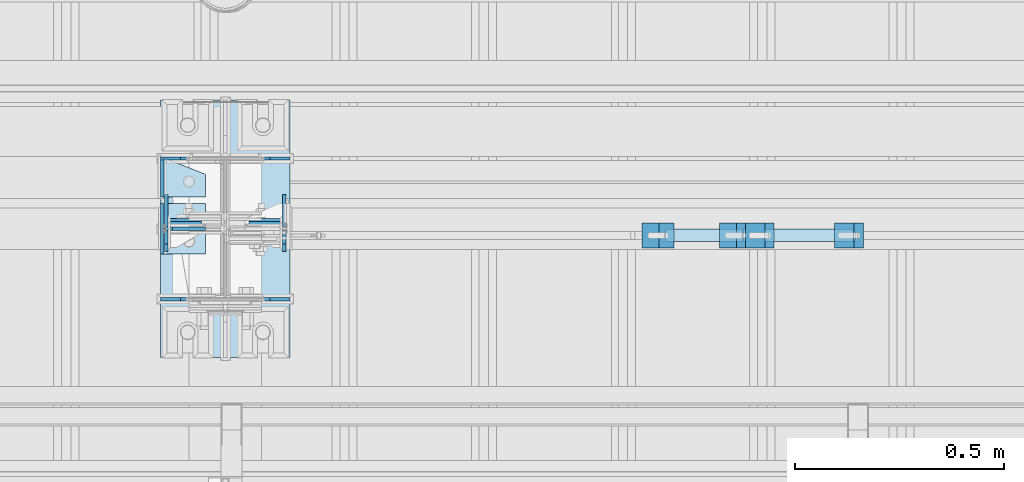
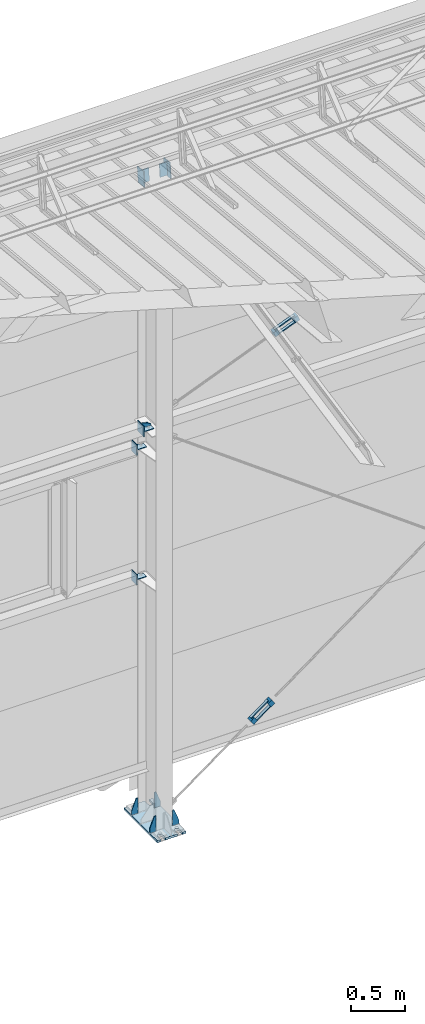
# One storey, part 140 of 709: 24 plates, 4 openings, 8 elements without a shape of their own.
"""IFC4 building model written with IfcOpenShell, lengths in millimetres."""

import ifcopenshell
import ifcopenshell.guid

model = None  # the IFC model being written
_history = None  # IfcOwnerHistory: only IFC2X3 demands one
_inside = {}  # id of a spatial element -> (the spatial element, [elements in it])
_under = {}  # id of a project, library or spatial element -> (it, [spatial elements below it])
_declared = {}  # id of a project -> (the project, [libraries it declares])
_typed = {}  # id of a type object -> (the type object, [elements of that type])
_made_of = {}  # id of a material, layer set ... -> (it, [elements and type objects made of it])


def new_model(schema):
    """Start an empty IFC model of exactly this schema.

    Asked for "IFC4X3", IfcOpenShell would pick the latest addendum, in which some entities
    have other attributes; the version numbers below select the first issue.
    IFC2X3 requires an IfcOwnerHistory on every rooted entity: one is made here for all.
    """
    global model, _history
    if schema == "IFC4X3":
        model = ifcopenshell.file(schema_version=(4, 3, 0, 0))
    else:
        model = ifcopenshell.file(schema=schema)
    _inside.clear()
    _under.clear()
    _declared.clear()
    _typed.clear()
    _made_of.clear()
    _history = None
    if model.schema == "IFC2X3":
        org = make("IfcOrganization", Name="unknown")
        user = make(
            "IfcPersonAndOrganization",
            ThePerson=make("IfcPerson", FamilyName="unknown"),
            TheOrganization=org,
        )
        app = make(
            "IfcApplication",
            ApplicationDeveloper=org,
            Version="unknown",
            ApplicationFullName="unknown",
            ApplicationIdentifier="unknown",
        )
        _history = make(
            "IfcOwnerHistory",
            OwningUser=user,
            OwningApplication=app,
            ChangeAction="ADDED",
            CreationDate=0,
        )
    return model


def make(cls, **values):
    """One entity of the class cls with the attributes given. An attribute that is None is left unset."""
    return model.create_entity(
        cls, **{name: value for name, value in values.items() if value is not None}
    )


def rooted(cls, **values):
    """An entity with a GlobalId (a new one), such as an element, a storey or a relation."""
    return make(cls, GlobalId=ifcopenshell.guid.new(), OwnerHistory=_history, **values)


def si_unit(unit_type, name, prefix=None):
    """IfcSIUnit, for example si_unit("LENGTHUNIT", "METRE", prefix="MILLI")."""
    return make("IfcSIUnit", UnitType=unit_type, Prefix=prefix, Name=name)


def assignment(units):
    """IfcUnitAssignment: the units of a project."""
    return None if units is None else make("IfcUnitAssignment", Units=units)


def point(xyz):
    """IfcCartesianPoint."""
    return None if xyz is None else make("IfcCartesianPoint", Coordinates=xyz)


def direction(xyz):
    """IfcDirection."""
    return None if xyz is None else make("IfcDirection", DirectionRatios=xyz)


def frame(location, z_axis=None, x_axis=None):
    """IfcAxis2Placement3D, a coordinate frame: its origin and axes. An axis left out is left unset."""
    return make(
        "IfcAxis2Placement3D",
        Location=point(location),
        Axis=direction(z_axis),
        RefDirection=direction(x_axis),
    )


def origin_with_axes():
    """The frame at (0, 0, 0) with the z axis (0, 0, 1) and the x axis (1, 0, 0) written out."""
    return frame((0.0, 0.0, 0.0), z_axis=(0.0, 0.0, 1.0), x_axis=(1.0, 0.0, 0.0))


def place(relative_to, where):
    """IfcLocalPlacement: puts the frame where relative to a parent placement (None: the world)."""
    return make(
        "IfcLocalPlacement", PlacementRelTo=relative_to, RelativePlacement=where
    )


def context(
    kind, dimensions, precision=None, world=None, true_north=None, identifier=None
):
    """IfcGeometricRepresentationContext, for example the 3D "Model" context."""
    return make(
        "IfcGeometricRepresentationContext",
        ContextIdentifier=identifier,
        ContextType=kind,
        CoordinateSpaceDimension=dimensions,
        Precision=precision,
        WorldCoordinateSystem=world,
        TrueNorth=true_north,
    )


def subcontext(parent, identifier, kind, view, scale=None):
    """IfcGeometricRepresentationSubContext, for example "Body" below "Model"."""
    return make(
        "IfcGeometricRepresentationSubContext",
        ContextIdentifier=identifier,
        ContextType=kind,
        ParentContext=parent,
        TargetScale=scale,
        TargetView=view,
    )


def project(units=None, contexts=None):
    """IfcProject with its units and contexts."""
    return rooted(
        "IfcProject",
        Name="project",
        RepresentationContexts=contexts,
        UnitsInContext=assignment(units),
    )


def spatial(cls, under=None, at=None, **own):
    """A site, building, storey or space (cls), placed at a placement, below another one or the project."""
    s = rooted(cls, ObjectPlacement=at, **own)
    if under is not None:
        _under.setdefault(under.id(), (under, []))[1].append(s)
    return s


def point_list(points):
    """IfcCartesianPointList2D or 3D."""
    cls = (
        "IfcCartesianPointList2D" if len(points[0]) == 2 else "IfcCartesianPointList3D"
    )
    return make(cls, CoordList=points)


def line(*indices):
    """IfcLineIndex: a straight run through numbered points of an indexed curve."""
    return model.create_entity("IfcLineIndex", indices)


def arc(*indices):
    """IfcArcIndex: an arc through three numbered points of an indexed curve."""
    return model.create_entity("IfcArcIndex", indices)


def indexed_curve(points, segments=None, self_intersect=None):
    """IfcIndexedPolyCurve: lines and arcs through numbered points (the first is 1)."""
    return make(
        "IfcIndexedPolyCurve",
        Points=point_list(points),
        Segments=segments,
        SelfIntersect=self_intersect,
    )


def outline(outer, holes=None, kind="AREA"):
    """IfcArbitraryClosedProfileDef: a profile drawn as a closed curve; with holes, ...WithVoids."""
    if holes is None:
        return make("IfcArbitraryClosedProfileDef", ProfileType=kind, OuterCurve=outer)
    return make(
        "IfcArbitraryProfileDefWithVoids",
        ProfileType=kind,
        OuterCurve=outer,
        InnerCurves=holes,
    )


def extrude(swept, where, along, depth):
    """IfcExtrudedAreaSolid: the profile swept, set in the frame where, extruded along a direction by depth."""
    return make(
        "IfcExtrudedAreaSolid",
        SweptArea=swept,
        Position=where,
        ExtrudedDirection=direction(along),
        Depth=depth,
    )


def shape(context_of_items, identifier, shape_type, items):
    """IfcShapeRepresentation: the items that make up one representation, for example the "Body"."""
    return make(
        "IfcShapeRepresentation",
        ContextOfItems=context_of_items,
        RepresentationIdentifier=identifier,
        RepresentationType=shape_type,
        Items=items,
    )


def material(Name=None, Category=None):
    """IfcMaterial."""
    return make("IfcMaterial", Name=Name, Category=Category)


def made_of(thing, what):
    """Note that an element or type object is made of a material, layer set ...; save() writes the relation."""
    if what is not None:
        _made_of.setdefault(what.id(), (what, []))[1].append(thing)
    return thing


def element(
    cls,
    number,
    at=None,
    inside=None,
    cuts=None,
    type_object=None,
    material=None,
    context=None,
    identifier="Body",
    shape_type=None,
    held_by="IfcProductDefinitionShape",
    body=None,
    shapes=None,
    **own,
):
    """One element of the class cls, such as IfcWall. Its Tag is "e" and its number.

    at: its placement. inside: the storey or other place that contains it. cuts: it is an
    opening in that element (IfcRelVoidsElement). A single representation is given by context,
    identifier, shape_type and body (its items); several are given by shapes. held_by: the class
    of the entity that holds the representations. save() writes the other relations.
    """
    e = rooted(cls, Tag="e%d" % number, ObjectPlacement=at, **own)
    if body is not None:
        shapes = [shape(context, identifier, shape_type, body)]
    if shapes is not None:
        e.Representation = make(held_by, Representations=shapes)
    if inside is not None:
        _inside.setdefault(inside.id(), (inside, []))[1].append(e)
    if cuts is not None:
        rooted(
            "IfcRelVoidsElement", RelatingBuildingElement=cuts, RelatedOpeningElement=e
        )
    if type_object is not None:
        _typed.setdefault(type_object.id(), (type_object, []))[1].append(e)
    return made_of(e, material)


def aggregate(whole, parts):
    """IfcRelAggregates: a whole, such as a stair, and the parts it consists of."""
    return rooted("IfcRelAggregates", RelatingObject=whole, RelatedObjects=parts)


def save(model, path):
    """Write the relations noted so far, then the file.

    IfcRelAggregates (storeys below a building ...), IfcRelContainedInSpatialStructure (elements
    in a storey), IfcRelDefinesByType, IfcRelAssociatesMaterial and IfcRelDeclares: one each for
    every whole, place, type object, material and project.
    """
    for whole, parts in _under.values():
        aggregate(whole, parts)
    for where, things in _inside.values():
        rooted(
            "IfcRelContainedInSpatialStructure",
            RelatedElements=things,
            RelatingStructure=where,
        )
    for kind, things in _typed.values():
        rooted("IfcRelDefinesByType", RelatedObjects=things, RelatingType=kind)
    for what, things in _made_of.values():
        rooted("IfcRelAssociatesMaterial", RelatedObjects=things, RelatingMaterial=what)
    for by, libraries in _declared.values():
        rooted("IfcRelDeclares", RelatingContext=by, RelatedDefinitions=libraries)
    model.write(path)


model = new_model("IFC4")

# Units and contexts
model_context = context("Model", 3, precision=0.2, world=origin_with_axes(), true_north=direction((0.0, 1.0)))
body_context = subcontext(model_context, "Body", "Model", "MODEL_VIEW")
ifc_project = project(units=[si_unit("LENGTHUNIT", "METRE", prefix="MILLI"), si_unit("AREAUNIT", "SQUARE_METRE"), si_unit("VOLUMEUNIT", "CUBIC_METRE"), si_unit("MASSUNIT", "GRAM", prefix="KILO"), si_unit("TIMEUNIT", "SECOND"), si_unit("PLANEANGLEUNIT", "RADIAN"), si_unit("SOLIDANGLEUNIT", "STERADIAN"), si_unit("THERMODYNAMICTEMPERATUREUNIT", "DEGREE_CELSIUS"), si_unit("LUMINOUSINTENSITYUNIT", "LUMEN")], contexts=[model_context])

# Site, building, storey
site_placement = place(None, origin_with_axes())
site = spatial("IfcSite", under=ifc_project, at=site_placement, CompositionType="ELEMENT")
building_placement = place(site_placement, origin_with_axes())
building = spatial("IfcBuilding", under=site, at=building_placement, Name="Undefined", CompositionType="ELEMENT")
storey_placement = place(building_placement, origin_with_axes())
storey = spatial("IfcBuildingStorey", under=building, at=storey_placement, Name="Undefined", CompositionType="ELEMENT", Elevation=0.0)

# Assembly, plates
assembly_1_placement = place(storey_placement, frame((23018.59299, 21841.0, 628.96003), z_axis=(0.8064830392, 0.0, 0.5912572262), x_axis=(0.0, -1.0, 0.0)))
assembly_1 = element("IfcElementAssembly", 1, at=assembly_1_placement, inside=storey)
ifc_material_1 = material(Name="Steel_Undefined", Category="STEEL")
plate_1_placement = place(assembly_1_placement, frame((15.0, 66.0, 230.0), z_axis=(0.0, 1.0, 0.0), x_axis=(1.0, 0.0, 0.0)))
plate_1 = element("IfcPlate", 2, at=plate_1_placement, material=ifc_material_1, ObjectType="484", context=body_context, shape_type="SolidModel", body=[
    extrude(outline(indexed_curve([(0.0, 0.0), (30.0, 0.0), (30.0, 230.0), (0.0, 230.0)], segments=[line(1, 2, 3, 4, 1)])), frame((0.0, 0.0, 6.0), z_axis=(0.0, 0.0, 1.0), x_axis=(1.0, 0.0, 0.0)), (0.0, 0.0, -1.0), 12.0),
])
plate_2_placement = place(assembly_1_placement, frame((15.0, -6.0, 230.0), z_axis=(0.0, 1.0, 0.0), x_axis=(1.0, 0.0, 0.0)))
plate_2 = element("IfcPlate", 3, at=plate_2_placement, material=ifc_material_1, ObjectType="484", context=body_context, shape_type="SolidModel", body=[
    extrude(outline(indexed_curve([(0.0, 0.0), (30.0, 0.0), (30.0, 230.0), (0.0, 230.0)], segments=[line(1, 2, 3, 4, 1)])), frame((0.0, 0.0, 6.0), z_axis=(0.0, 0.0, 1.0), x_axis=(1.0, 0.0, 0.0)), (0.0, 0.0, -1.0), 12.0),
])
plate_3_placement = place(assembly_1_placement, frame((0.0, 0.0, 230.0), z_axis=(0.0, 0.0, 1.0), x_axis=(1.0, 0.0, 0.0)))
plate_3 = element("IfcPlate", 4, at=plate_3_placement, material=ifc_material_1, ObjectType="483", context=body_context, shape_type="SolidModel", body=[
    extrude(outline(indexed_curve([(0.0, 0.0), (60.0, 0.0), (60.0, 60.0), (0.0, 60.0)], segments=[line(1, 2, 3, 4, 1)])), frame((0.0, 0.0, 25.0), z_axis=(0.0, 0.0, 1.0), x_axis=(1.0, 0.0, 0.0)), (0.0, 0.0, -1.0), 50.0),
])
plate_4_placement = place(assembly_1_placement, origin_with_axes())
plate_4 = element("IfcPlate", 5, at=plate_4_placement, material=ifc_material_1, ObjectType="482", context=body_context, shape_type="SolidModel", body=[
    extrude(outline(indexed_curve([(0.0, 0.0), (60.0, 0.0), (60.0, 60.0), (0.0, 60.0)], segments=[line(1, 2, 3, 4, 1)])), frame((0.0, 0.0, 25.0), z_axis=(0.0, 0.0, 1.0), x_axis=(1.0, 0.0, 0.0)), (0.0, 0.0, -1.0), 50.0),
])
aggregate(assembly_1, [plate_1, plate_2, plate_3, plate_4])

assembly_2_placement = place(storey_placement, frame((23269.12737, 21841.0, 4944.67799), z_axis=(0.9286065, 0.0, 0.371065989), x_axis=(0.0, -1.0, 0.0)))
assembly_2 = element("IfcElementAssembly", 6, at=assembly_2_placement, inside=storey)
plate_5_placement = place(assembly_2_placement, origin_with_axes())
plate_5 = element("IfcPlate", 7, at=plate_5_placement, material=ifc_material_1, ObjectType="482", context=body_context, shape_type="SolidModel", body=[
    extrude(outline(indexed_curve([(0.0, 0.0), (60.0, 0.0), (60.0, 60.0), (0.0, 60.0)], segments=[line(1, 2, 3, 4, 1)])), frame((0.0, 0.0, 25.0), z_axis=(0.0, 0.0, 1.0), x_axis=(1.0, 0.0, 0.0)), (0.0, 0.0, -1.0), 50.0),
])
plate_6_placement = place(assembly_2_placement, frame((0.0, 0.0, 230.0), z_axis=(0.0, 0.0, 1.0), x_axis=(1.0, 0.0, 0.0)))
plate_6 = element("IfcPlate", 8, at=plate_6_placement, material=ifc_material_1, ObjectType="483", context=body_context, shape_type="SolidModel", body=[
    extrude(outline(indexed_curve([(0.0, 0.0), (60.0, 0.0), (60.0, 60.0), (0.0, 60.0)], segments=[line(1, 2, 3, 4, 1)])), frame((0.0, 0.0, 25.0), z_axis=(0.0, 0.0, 1.0), x_axis=(1.0, 0.0, 0.0)), (0.0, 0.0, -1.0), 50.0),
])
plate_7_placement = place(assembly_2_placement, frame((15.0, -6.0, 230.0), z_axis=(0.0, 1.0, 0.0), x_axis=(1.0, 0.0, 0.0)))
plate_7 = element("IfcPlate", 9, at=plate_7_placement, material=ifc_material_1, ObjectType="484", context=body_context, shape_type="SolidModel", body=[
    extrude(outline(indexed_curve([(0.0, 0.0), (30.0, 0.0), (30.0, 230.0), (0.0, 230.0)], segments=[line(1, 2, 3, 4, 1)])), frame((0.0, 0.0, 6.0), z_axis=(0.0, 0.0, 1.0), x_axis=(1.0, 0.0, 0.0)), (0.0, 0.0, -1.0), 12.0),
])
plate_8_placement = place(assembly_2_placement, frame((15.0, 66.0, 230.0), z_axis=(0.0, 1.0, 0.0), x_axis=(1.0, 0.0, 0.0)))
plate_8 = element("IfcPlate", 10, at=plate_8_placement, material=ifc_material_1, ObjectType="484", context=body_context, shape_type="SolidModel", body=[
    extrude(outline(indexed_curve([(0.0, 0.0), (30.0, 0.0), (30.0, 230.0), (0.0, 230.0)], segments=[line(1, 2, 3, 4, 1)])), frame((0.0, 0.0, 6.0), z_axis=(0.0, 0.0, 1.0), x_axis=(1.0, 0.0, 0.0)), (0.0, 0.0, -1.0), 12.0),
])
aggregate(assembly_2, [plate_5, plate_6, plate_7, plate_8])

# Assembly, plates, voiding features
assembly_3_placement = place(storey_placement, frame((22000.0, 21827.0, -200.0), z_axis=(-1.0, 0.0, 0.0), x_axis=(0.0, 0.0, 1.0)))
assembly_3 = element("IfcElementAssembly", 11, at=assembly_3_placement, inside=storey)
ifc_material_2 = material(Name="C355-6", Category="STEEL")
plate_9_placement = place(assembly_3_placement, frame((25.0, -168.5, -87.0), z_axis=(0.0, -1.0, 0.0), x_axis=(0.0, 0.0, -1.0)))
plate_9 = element("IfcPlate", 12, at=plate_9_placement, material=ifc_material_2, ObjectType="419", context=body_context, shape_type="SolidModel", body=[
    extrude(outline(indexed_curve([(0.0, 0.0), (68.0, 0.0), (68.0, 50.0), (20.0, 175.0), (0.0, 175.0)], segments=[line(1, 2, 3, 4, 5, 1)])), frame((0.0, 0.0, 4.0), z_axis=(0.0, 0.0, 1.0), x_axis=(1.0, 0.0, 0.0)), (0.0, 0.0, -1.0), 8.0),
])
plate_10_placement = place(assembly_3_placement, frame((25.0, 168.5, -87.0), z_axis=(0.0, -1.0, 0.0), x_axis=(0.0, 0.0, -1.0)))
plate_10 = element("IfcPlate", 13, at=plate_10_placement, material=ifc_material_2, ObjectType="419", context=body_context, shape_type="SolidModel", body=[
    extrude(outline(indexed_curve([(0.0, 0.0), (68.0, 0.0), (68.0, 50.0), (20.0, 175.0), (0.0, 175.0)], segments=[line(1, 2, 3, 4, 5, 1)])), frame((0.0, 0.0, 4.0), z_axis=(0.0, 0.0, 1.0), x_axis=(1.0, 0.0, 0.0)), (0.0, 0.0, -1.0), 8.0),
])
plate_11_placement = place(assembly_3_placement, frame((25.0, 168.5, 87.0), z_axis=(0.0, 1.0, 0.0), x_axis=(0.0, 0.0, 1.0)))
plate_11 = element("IfcPlate", 14, at=plate_11_placement, material=ifc_material_2, ObjectType="419", context=body_context, shape_type="SolidModel", body=[
    extrude(outline(indexed_curve([(0.0, 0.0), (68.0, 0.0), (68.0, 50.0), (20.0, 175.0), (0.0, 175.0)], segments=[line(1, 2, 3, 4, 5, 1)])), frame((0.0, 0.0, 4.0), z_axis=(0.0, 0.0, 1.0), x_axis=(1.0, 0.0, 0.0)), (0.0, 0.0, -1.0), 8.0),
])
plate_12_placement = place(assembly_3_placement, frame((25.0, -168.5, 87.0), z_axis=(0.0, 1.0, 0.0), x_axis=(0.0, 0.0, 1.0)))
plate_12 = element("IfcPlate", 15, at=plate_12_placement, material=ifc_material_2, ObjectType="419", context=body_context, shape_type="SolidModel", body=[
    extrude(outline(indexed_curve([(0.0, 0.0), (68.0, 0.0), (68.0, 50.0), (20.0, 175.0), (0.0, 175.0)], segments=[line(1, 2, 3, 4, 5, 1)])), frame((0.0, 0.0, 4.0), z_axis=(0.0, 0.0, 1.0), x_axis=(1.0, 0.0, 0.0)), (0.0, 0.0, -1.0), 8.0),
])
plate_13_placement = place(assembly_3_placement, frame((12.5, -308.0, 155.0), z_axis=(1.0, 0.0, 0.0), x_axis=(0.0, 0.0, -1.0)))
plate_13 = element("IfcPlate", 16, at=plate_13_placement, material=ifc_material_2, context=body_context, shape_type="SolidModel", body=[
    extrude(outline(indexed_curve([(0.0, 0.0), (310.0, 0.0), (310.0, 616.0), (0.0, 616.0)], segments=[line(1, 2, 3, 4, 1)])), frame((0.0, 0.0, 12.5), z_axis=(0.0, 0.0, 1.0), x_axis=(1.0, 0.0, 0.0)), (0.0, 0.0, -1.0), 25.0),
])
voiding_feature_1_placement = place(plate_13_placement, frame((40.0, 616.0, 0.0), z_axis=(0.0, 0.0, -1.0), x_axis=(1.0, 0.0, 0.0)))
element("IfcVoidingFeature", 17, at=voiding_feature_1_placement, cuts=plate_13, PredefinedType="HOLE", context=body_context, shape_type="SolidModel", body=[
    extrude(outline(indexed_curve([(0.0, 0.0), (50.0, 0.0), (50.0, 60.0), (42.67767, 77.67767), (25.0, 85.0), (25.0, 85.0), (7.32233, 77.67767), (0.0, 60.0)], segments=[line(1, 2, 3), arc(3, 4, 5), line(5, 6), arc(6, 7, 8), line(8, 1)])), frame((0.0, 0.0, 12.5), z_axis=(0.0, 0.0, 1.0), x_axis=(1.0, 0.0, 0.0)), (0.0, 0.0, -1.0), 25.0),
])
voiding_feature_2_placement = place(plate_13_placement, frame((40.0, 0.0, 0.0), z_axis=(0.0, 0.0, 1.0), x_axis=(1.0, 0.0, 0.0)))
element("IfcVoidingFeature", 18, at=voiding_feature_2_placement, cuts=plate_13, PredefinedType="HOLE", context=body_context, shape_type="SolidModel", body=[
    extrude(outline(indexed_curve([(0.0, 0.0), (50.0, 0.0), (50.0, 60.0), (42.67767, 77.67767), (25.0, 85.0), (25.0, 85.0), (7.32233, 77.67767), (0.0, 60.0)], segments=[line(1, 2, 3), arc(3, 4, 5), line(5, 6), arc(6, 7, 8), line(8, 1)])), frame((0.0, 0.0, 12.5), z_axis=(0.0, 0.0, 1.0), x_axis=(1.0, 0.0, 0.0)), (0.0, 0.0, -1.0), 25.0),
])
voiding_feature_3_placement = place(plate_13_placement, frame((270.0, 616.0, 0.0), z_axis=(0.0, 0.0, 1.0), x_axis=(-1.0, 0.0, 0.0)))
element("IfcVoidingFeature", 19, at=voiding_feature_3_placement, cuts=plate_13, PredefinedType="HOLE", context=body_context, shape_type="SolidModel", body=[
    extrude(outline(indexed_curve([(0.0, 0.0), (50.0, 0.0), (50.0, 60.0), (42.67767, 77.67767), (25.0, 85.0), (25.0, 85.0), (7.32233, 77.67767), (0.0, 60.0)], segments=[line(1, 2, 3), arc(3, 4, 5), line(5, 6), arc(6, 7, 8), line(8, 1)])), frame((0.0, 0.0, 12.5), z_axis=(0.0, 0.0, 1.0), x_axis=(1.0, 0.0, 0.0)), (0.0, 0.0, -1.0), 25.0),
])
voiding_feature_4_placement = place(plate_13_placement, frame((270.0, 0.0, 0.0), z_axis=(0.0, 0.0, -1.0), x_axis=(-1.0, 0.0, 0.0)))
element("IfcVoidingFeature", 20, at=voiding_feature_4_placement, cuts=plate_13, PredefinedType="HOLE", context=body_context, shape_type="SolidModel", body=[
    extrude(outline(indexed_curve([(0.0, 0.0), (50.0, 0.0), (50.0, 60.0), (42.67767, 77.67767), (25.0, 85.0), (25.0, 85.0), (7.32233, 77.67767), (0.0, 60.0)], segments=[line(1, 2, 3), arc(3, 4, 5), line(5, 6), arc(6, 7, 8), line(8, 1)])), frame((0.0, 0.0, 12.5), z_axis=(0.0, 0.0, 1.0), x_axis=(1.0, 0.0, 0.0)), (0.0, 0.0, -1.0), 25.0),
])
aggregate(assembly_3, [plate_9, plate_10, plate_11, plate_12, plate_13])

# Assembly, plates
assembly_4_placement = place(storey_placement, frame((22000.0, 21950.0, 2550.0), z_axis=(0.0, 0.0, -1.0), x_axis=(-1.0, 0.0, 0.0)))
assembly_4 = element("IfcElementAssembly", 21, at=assembly_4_placement, inside=storey)
plate_14_placement = place(assembly_4_placement, frame((151.0, 47.0, -60.0), z_axis=(-1.0, 0.0, 0.0), x_axis=(0.0, -1.0, 0.0)))
plate_14 = element("IfcPlate", 22, at=plate_14_placement, material=ifc_material_2, ObjectType="501", context=body_context, shape_type="SolidModel", body=[
    extrude(outline(indexed_curve([(0.0, 0.0), (94.0, 0.0), (94.0, 120.0), (0.0, 120.0)], segments=[line(1, 2, 3, 4, 1)])), frame((0.0, 0.0, 4.0), z_axis=(0.0, 0.0, 1.0), x_axis=(1.0, 0.0, 0.0)), (0.0, 0.0, -1.0), 8.0),
])
plate_15_placement = place(assembly_4_placement, frame((47.0, 47.0, 0.0), z_axis=(0.0, 0.0, 1.0), x_axis=(0.0, -1.0, 0.0)))
plate_15 = element("IfcPlate", 23, at=plate_15_placement, material=ifc_material_2, ObjectType="502", context=body_context, shape_type="SolidModel", body=[
    extrude(outline(indexed_curve([(0.0, 100.0), (40.0, 0.0), (94.0, 0.0), (94.0, 100.0), (0.0, 100.0)], segments=[line(1, 2, 3, 4, 5, 1)])), frame((0.0, 0.0, 4.0), z_axis=(0.0, 0.0, 1.0), x_axis=(1.0, 0.0, 0.0)), (0.0, 0.0, -1.0), 8.0),
])
aggregate(assembly_4, [plate_14, plate_15])

assembly_5_placement = place(storey_placement, frame((22000.0, 21950.0, 4020.0), z_axis=(0.0, 0.0, -1.0), x_axis=(-1.0, 0.0, 0.0)))
assembly_5 = element("IfcElementAssembly", 24, at=assembly_5_placement, inside=storey)
plate_16_placement = place(assembly_5_placement, frame((151.0, 47.0, -60.0), z_axis=(-1.0, 0.0, 0.0), x_axis=(0.0, -1.0, 0.0)))
plate_16 = element("IfcPlate", 25, at=plate_16_placement, material=ifc_material_2, ObjectType="501", context=body_context, shape_type="SolidModel", body=[
    extrude(outline(indexed_curve([(0.0, 0.0), (94.0, 0.0), (94.0, 120.0), (0.0, 120.0)], segments=[line(1, 2, 3, 4, 1)])), frame((0.0, 0.0, 4.0), z_axis=(0.0, 0.0, 1.0), x_axis=(1.0, 0.0, 0.0)), (0.0, 0.0, -1.0), 8.0),
])
plate_17_placement = place(assembly_5_placement, frame((47.0, 47.0, 0.0), z_axis=(0.0, 0.0, 1.0), x_axis=(0.0, -1.0, 0.0)))
plate_17 = element("IfcPlate", 26, at=plate_17_placement, material=ifc_material_2, ObjectType="502", context=body_context, shape_type="SolidModel", body=[
    extrude(outline(indexed_curve([(0.0, 100.0), (40.0, 0.0), (94.0, 0.0), (94.0, 100.0), (0.0, 100.0)], segments=[line(1, 2, 3, 4, 5, 1)])), frame((0.0, 0.0, 4.0), z_axis=(0.0, 0.0, 1.0), x_axis=(1.0, 0.0, 0.0)), (0.0, 0.0, -1.0), 8.0),
])
aggregate(assembly_5, [plate_16, plate_17])

assembly_6_placement = place(storey_placement, frame((22000.0, 21827.0, 4310.0), z_axis=(0.0, 0.0, -1.0), x_axis=(-1.0, 0.0, 0.0)))
assembly_6 = element("IfcElementAssembly", 27, at=assembly_6_placement, inside=storey)
plate_18_placement = place(assembly_6_placement, frame((47.0, 0.0, -60.0), z_axis=(0.0, 1.0, 0.0), x_axis=(0.0, 0.0, 1.0)))
plate_18 = element("IfcPlate", 28, at=plate_18_placement, material=ifc_material_2, ObjectType="508", context=body_context, shape_type="SolidModel", body=[
    extrude(outline(indexed_curve([(0.0, 80.0), (36.0, 0.0), (56.0, 0.0), (56.0, 90.0), (46.0, 100.0), (0.0, 100.0)], segments=[line(1, 2, 3, 4, 5, 6, 1)])), frame((0.0, 0.0, 4.0), z_axis=(0.0, 0.0, 1.0), x_axis=(1.0, 0.0, 0.0)), (0.0, 0.0, -1.0), 8.0),
])
plate_19_placement = place(assembly_6_placement, frame((151.0, 60.0, 60.0), z_axis=(-1.0, 0.0, 0.0), x_axis=(0.0, 0.0, -1.0)))
plate_19 = element("IfcPlate", 29, at=plate_19_placement, material=ifc_material_2, ObjectType="506", context=body_context, shape_type="SolidModel", body=[
    extrude(outline(indexed_curve([(0.0, 0.0), (120.0, 0.0), (120.0, 120.0), (0.0, 120.0)], segments=[line(1, 2, 3, 4, 1)])), frame((0.0, 0.0, 4.0), z_axis=(0.0, 0.0, 1.0), x_axis=(1.0, 0.0, 0.0)), (0.0, 0.0, -1.0), 8.0),
])
plate_20_placement = place(assembly_6_placement, frame((47.0, 60.0, 0.0), z_axis=(0.0, 0.0, 1.0), x_axis=(0.0, -1.0, 0.0)))
plate_20 = element("IfcPlate", 30, at=plate_20_placement, material=ifc_material_2, ObjectType="507", context=body_context, shape_type="SolidModel", body=[
    extrude(outline(indexed_curve([(0.0, 0.0), (120.0, 0.0), (120.0, 100.0), (0.0, 100.0)], segments=[line(1, 2, 3, 4, 1)])), frame((0.0, 0.0, 4.0), z_axis=(0.0, 0.0, 1.0), x_axis=(1.0, 0.0, 0.0)), (0.0, 0.0, -1.0), 8.0),
])
aggregate(assembly_6, [plate_18, plate_19, plate_20])

assembly_7_placement = place(storey_placement, frame((22000.0, 21841.04467, 7154.40952), z_axis=(0.0, -0.9950371902, 0.099503719), x_axis=(-1.0, 0.0, 0.0)))
assembly_7 = element("IfcElementAssembly", 31, at=assembly_7_placement, inside=storey)
plate_21_placement = place(assembly_7_placement, frame((57.0, -72.0, 0.0), z_axis=(0.0, 0.0, 1.0), x_axis=(1.0, 0.0, 0.0)))
plate_21 = element("IfcPlate", 32, at=plate_21_placement, material=ifc_material_2, ObjectType="597", context=body_context, shape_type="SolidModel", body=[
    extrude(outline(indexed_curve([(0.0, 0.0), (80.0, 0.0), (80.0, 144.0), (0.0, 144.0)], segments=[line(1, 2, 3, 4, 1)])), frame((0.0, 0.0, 4.0), z_axis=(0.0, 0.0, 1.0), x_axis=(1.0, 0.0, 0.0)), (0.0, 0.0, -1.0), 8.0),
])
plate_22_placement = place(assembly_7_placement, frame((141.0, -87.0, -60.0), z_axis=(-1.0, 0.0, 0.0), x_axis=(0.0, 0.0, 1.0)))
plate_22 = element("IfcPlate", 33, at=plate_22_placement, material=ifc_material_2, ObjectType="596", context=body_context, shape_type="SolidModel", body=[
    extrude(outline(indexed_curve([(0.0, 0.0), (120.0, 0.0), (120.0, 174.0), (0.0, 174.0)], segments=[line(1, 2, 3, 4, 1)])), frame((0.0, 0.0, 4.0), z_axis=(0.0, 0.0, 1.0), x_axis=(1.0, 0.0, 0.0)), (0.0, 0.0, -1.0), 8.0),
])
aggregate(assembly_7, [plate_21, plate_22])

assembly_8_placement = place(storey_placement, frame((28000.0, 21841.04467, 7154.40952), z_axis=(0.0, -0.9950371902, 0.099503719), x_axis=(-1.0, 0.0, 0.0)))
assembly_8 = element("IfcElementAssembly", 34, at=assembly_8_placement, inside=storey)
plate_23_placement = place(assembly_8_placement, frame((5943.0, 72.0, 0.0), z_axis=(0.0, 0.0, 1.0), x_axis=(-1.0, 0.0, 0.0)))
plate_23 = element("IfcPlate", 35, at=plate_23_placement, material=ifc_material_2, ObjectType="597", context=body_context, shape_type="SolidModel", body=[
    extrude(outline(indexed_curve([(0.0, 0.0), (80.0, 0.0), (80.0, 144.0), (0.0, 144.0)], segments=[line(1, 2, 3, 4, 1)])), frame((0.0, 0.0, 4.0), z_axis=(0.0, 0.0, 1.0), x_axis=(1.0, 0.0, 0.0)), (0.0, 0.0, -1.0), 8.0),
])
plate_24_placement = place(assembly_8_placement, frame((5859.0, -87.0, 60.0), z_axis=(1.0, 0.0, 0.0), x_axis=(0.0, 0.0, -1.0)))
plate_24 = element("IfcPlate", 36, at=plate_24_placement, material=ifc_material_2, ObjectType="596", context=body_context, shape_type="SolidModel", body=[
    extrude(outline(indexed_curve([(0.0, 0.0), (120.0, 0.0), (120.0, 174.0), (0.0, 174.0)], segments=[line(1, 2, 3, 4, 1)])), frame((0.0, 0.0, 4.0), z_axis=(0.0, 0.0, 1.0), x_axis=(1.0, 0.0, 0.0)), (0.0, 0.0, -1.0), 8.0),
])
aggregate(assembly_8, [plate_23, plate_24])

save(model, "model.ifc")
